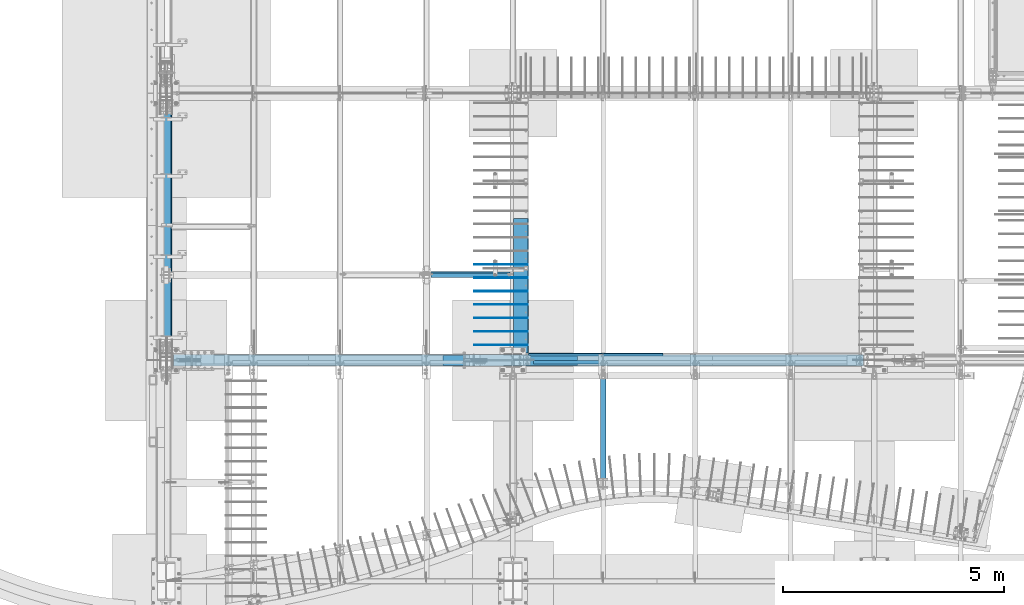
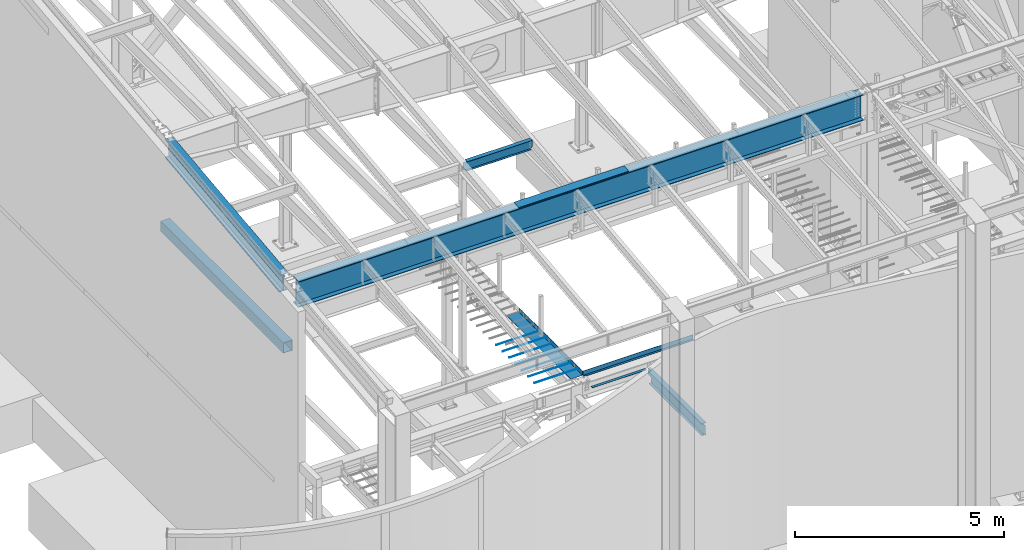
# One storey, part 706 of 1179: 16 beams, 14 elements without a shape of their own.
"""IFC2X3 building model written with IfcOpenShell, lengths in millimetres."""

from ifc_helpers import new_model, si_unit, frame, origin_with_axes, place, context, subcontext, project, spatial, faceted_brep, material, type_object, element, aggregate, save


model = new_model("IFC2X3")

# Units and contexts
model_context = context("Model", 3, precision=1e-05, world=origin_with_axes())
body_context = subcontext(model_context, "Body", "Model", "MODEL_VIEW")
ifc_project = project(units=[si_unit("LENGTHUNIT", "METRE", prefix="MILLI"), si_unit("AREAUNIT", "SQUARE_METRE"), si_unit("VOLUMEUNIT", "CUBIC_METRE"), si_unit("MASSUNIT", "GRAM", prefix="KILO"), si_unit("TIMEUNIT", "SECOND"), si_unit("PLANEANGLEUNIT", "RADIAN"), si_unit("SOLIDANGLEUNIT", "STERADIAN"), si_unit("THERMODYNAMICTEMPERATUREUNIT", "DEGREE_CELSIUS"), si_unit("LUMINOUSINTENSITYUNIT", "LUMEN")], contexts=[model_context])

# Site, building, storey
site_placement = place(None, origin_with_axes())
site = spatial("IfcSite", under=ifc_project, at=site_placement, CompositionType="ELEMENT")
building_placement = place(site_placement, origin_with_axes())
building = spatial("IfcBuilding", under=site, at=building_placement, Name="Undefined", CompositionType="ELEMENT")
storey_placement = place(building_placement, origin_with_axes())
storey = spatial("IfcBuildingStorey", under=building, at=storey_placement, Name="Undefined", CompositionType="ELEMENT", Elevation=0.0)

# Assembly, beam
assembly_1_placement = place(storey_placement, origin_with_axes())
assembly_1 = element("IfcElementAssembly", 1, at=assembly_1_placement, inside=storey, Name="BEAM", AssemblyPlace="NOTDEFINED", PredefinedType="RIGID_FRAME")
ifc_material_1 = material(Name="STEEL/A992")
beam_type_1 = type_object("IfcBeamType", Name="W12X14", PredefinedType="NOTDEFINED")
beam_1_placement = place(assembly_1_placement, frame((6324.6, 7382.95051456451, 9929.37147871498), z_axis=(0.0, -0.11280435903861, 0.993617218340085), x_axis=(1.0, 0.0, 0.0)))
beam_1 = element("IfcBeam", 2, at=beam_1_placement, type_object=beam_type_1, material=ifc_material_1, Name="BEAM", ObjectType="W12X14", context=body_context, shape_type="Brep", body=[
    faceted_brep([(15.875, -2.38124999998217, -125.412500001823), (15.875, 2.38125000001673, -125.412500001821), (85.725000190735, 2.38125000001673, -125.412500001734), (85.725000190735, -2.38124999998035, -125.412500001727), (90.5850797087805, 2.38125000001673, -126.379229924321), (90.5850797087805, -2.38124999998035, -126.379229924314), (94.7052561769342, 2.38125000001855, -129.132243824804), (94.7052561769342, -2.38124999998035, -129.132243824799), (97.4582700774126, 2.38125000001855, -133.252420292965), (97.4582700774126, -2.38124999998035, -133.252420292958), (98.4250000000002, -2.38124999997854, -138.112499811014), (98.4250000000002, 2.38125000001855, -138.112499811021), (98.4250000000002, 2.38125000002037, -144.462500000087), (98.4250000000002, 50.7999999999993, -144.46250000012), (98.4250000000002, 50.8000000000011, -150.812500000122), (98.4250000000002, -50.7999999999574, -150.812500000055), (98.4250000000002, -50.7999999999574, -144.462500000051), (98.4250000000002, -2.38124999997854, -144.462500000083), (1889.91875, 50.7999999999593, 144.462500000054), (1889.91875, 2.38124999997854, 144.462500000085), (98.4250000000002, 2.38124999997854, 144.462500000085), (98.4250000000002, 50.7999999999593, 144.462500000054), (85.725000190735, -2.38125000001673, 125.412499998731), (85.725000190735, 2.38124999998035, 125.412499998723), (15.875, 2.38124999998217, 125.412499998634), (15.875, -2.38125000001673, 125.412499998632), (90.5850797087805, -2.38125000001673, 126.379229921322), (90.5850797087805, 2.38124999998217, 126.379229921315), (94.7052561769342, -2.38125000001673, 129.132243821803), (94.7052561769342, 2.38124999998035, 129.132243821796), (97.4582700774126, -2.38125000001855, 133.252420289966), (97.4582700774126, 2.38124999998035, 133.252420289959), (98.4250000000002, -2.38125000001855, 138.112499808019), (98.4250000000002, 2.38124999998035, 138.11249980801), (1889.91875, -50.7999999999993, 150.812500000124), (1889.91875, 50.7999999999574, 150.812500000058), (98.4250000000002, 50.7999999999574, 150.812500000058), (98.4250000000002, -50.7999999999993, 150.812500000124), (1889.91875, -50.7999999999993, 144.46250000012), (98.4250000000002, -50.7999999999993, 144.46250000012), (1889.91875, -2.38125000001855, 144.462500000089), (98.4250000000002, -2.38125000001855, 144.462500000089), (1890.88547992258, -2.38125000001855, 139.602420289955), (1890.88547992258, 2.38124999998035, 139.60242028995), (1893.63849382306, -2.38125000001855, 135.482243821796), (1893.63849382306, 2.38124999998035, 135.482243821787), (1897.75867029122, -2.38125000001855, 132.729229921311), (1897.75867029122, 2.38124999998035, 132.729229921306), (1902.61874980926, -2.38125000001855, 131.762499998722), (1902.61874980926, 2.38124999998035, 131.762499998715), (1940.71875, -2.38125000001673, 131.762499998811), (1940.71875, 2.38124999998035, 131.762499998813), (1940.71875, 2.38125000001673, -117.887500003169), (1940.71875, 2.38124999998399, 112.712499998535), (1940.71875, -2.38124999998035, -131.762500001627), (1940.71875, 2.38125000001855, -131.762500001627), (1902.61874980926, -2.38124999998035, -131.76250000172), (1902.61874980926, 2.38125000001855, -131.762500001725), (1897.75867029122, -2.38124999997854, -132.729229924307), (1897.75867029122, 2.38125000001855, -132.729229924314), (1893.63849382306, -2.38124999997854, -135.48224382479), (1893.63849382306, 2.38125000001855, -135.482243824797), (1890.88547992258, -2.38124999997854, -139.602420292951), (1890.88547992258, 2.38125000001855, -139.602420292958), (1889.91875, -2.38124999997854, -144.462500000083), (1889.91875, 2.38125000002037, -144.462500000087), (1889.91875, -50.7999999999574, -144.462500000051), (1889.91875, -50.7999999999574, -150.812500000055), (1889.91875, 50.8000000000011, -150.812500000122), (1889.91875, 50.7999999999993, -144.46250000012), (15.875, 2.38125000001673, -117.887500002969), (15.875, 2.38124999998399, 112.71249999857)], [[[0, 1, 2, 3]], [[3, 2, 4, 5]], [[5, 4, 6, 7]], [[7, 6, 8, 9]], [[10, 11, 12, 13, 14, 15, 16, 17]], [[9, 8, 11, 10]], [[18, 19, 20, 21]], [[22, 23, 24, 25]], [[26, 27, 23, 22]], [[28, 29, 27, 26]], [[30, 31, 29, 28]], [[32, 33, 31, 30]], [[34, 35, 36, 37]], [[38, 34, 37, 39]], [[40, 38, 39, 41]], [[37, 36, 21, 20, 33, 32, 41, 39]], [[35, 18, 21, 36]], [[34, 38, 40, 19, 18, 35]], [[42, 43, 19, 40]], [[44, 45, 43, 42]], [[46, 47, 45, 44]], [[48, 49, 47, 46]], [[50, 51, 49, 48]], [[52, 53, 51, 50, 54, 55]], [[54, 56, 57, 55]], [[58, 59, 57, 56]], [[60, 61, 59, 58]], [[62, 63, 61, 60]], [[64, 65, 63, 62]], [[66, 67, 68, 69, 65, 64]], [[66, 64, 17, 16]], [[67, 66, 16, 15]], [[68, 67, 15, 14]], [[69, 68, 14, 13]], [[65, 69, 13, 12]], [[6, 4, 2, 1, 70, 71, 24, 23, 27, 29, 31, 33, 20, 19, 43, 45, 47, 49, 51, 53, 52, 55, 57, 59, 61, 63, 65, 12, 11, 8]], [[25, 24, 71, 70, 1, 0]], [[64, 62, 60, 58, 56, 54, 50, 48, 46, 44, 42, 40, 41, 32, 30, 28, 26, 22, 25, 0, 3, 5, 7, 9, 10, 17]]]),
])
aggregate(assembly_1, [beam_1])

assembly_2_placement = place(storey_placement, origin_with_axes())
assembly_2 = element("IfcElementAssembly", 3, at=assembly_2_placement, inside=storey, Name="BEAM", AssemblyPlace="NOTDEFINED", PredefinedType="RIGID_FRAME")
ifc_material_2 = material(Name="STEEL/A36")
beam_type_2 = type_object("IfcBeamType", PredefinedType="NOTDEFINED")
beam_2_placement = place(assembly_2_placement, frame((10150.475, 5597.525, 4235.45000610352), z_axis=(1.0, 0.0, 0.0), x_axis=(0.0, 0.0, -1.0)))
beam_2 = element("IfcBeam", 4, at=beam_2_placement, type_object=beam_type_2, material=ifc_material_2, Name="BENT_PLATE", context=body_context, shape_type="Brep", body=[
    faceted_brep([(133.350006103516, -47.6250000000027, -1463.675), (127.000006103515, -47.6250000000027, -1463.675), (127.000006103512, -47.6249999999927, -1524.0), (133.350006103512, -47.6249999999927, -1524.0), (133.350006103516, -60.3250000000016, -1463.675), (127.000006103515, -60.3250000000016, -1463.675), (0.0, 3.17499999999927, -1524.0), (6.00266503170133e-10, 3.17500000077416, 1524.00000000052), (133.350006103513, 3.17500000000291, 1524.0), (133.350006103513, 3.17500000000291, -1524.0), (0.0, -3.17499999999927, -1524.0), (6.00266503170133e-10, -3.17499999922438, 1524.00000000052), (127.000006103513, -3.17500000000291, -1524.0), (127.000006103513, -3.17500000000291, 1524.0), (127.000006103515, -60.3250000000016, 1524.0), (133.350006103516, -60.3250000000016, 1524.0)], [[[0, 1, 2, 3]], [[4, 5, 1, 0]], [[6, 7, 8, 9]], [[10, 11, 7, 6]], [[11, 10, 12, 13]], [[8, 7, 11, 13, 14, 15]], [[3, 9, 8, 15, 4, 0]], [[12, 10, 6, 9, 3, 2]], [[14, 13, 12, 2, 1, 5]], [[15, 14, 5, 4]]]),
])

assembly_3_placement = place(storey_placement, origin_with_axes())
assembly_3 = element("IfcElementAssembly", 5, at=assembly_3_placement, inside=storey, Name="BEAM", AssemblyPlace="NOTDEFINED", PredefinedType="RIGID_FRAME")
beam_type_3 = type_object("IfcBeamType", PredefinedType="NOTDEFINED")
beam_3_placement = place(assembly_3_placement, frame((8220.07499932826, 5543.55933465687, 9826.91628422072), z_axis=(-1.0, 0.0, 0.0), x_axis=(0.0, 0.0, 1.0)))
beam_3 = element("IfcBeam", 6, at=beam_3_placement, type_object=beam_type_3, material=ifc_material_2, Name="BENT_PLATE", context=body_context, shape_type="Brep", body=[
    faceted_brep([(-2.91038304567337e-11, -4.76250000000073, -1524.0), (-2.91038304567337e-11, -4.76250000000073, 1524.0), (2.91038304567337e-11, 4.76250000000073, 1524.0), (2.91038304567337e-11, 4.76250000000073, -1524.0), (46.9151566473611, 4.76249999974698, 1524.0), (46.9151566473611, 4.76249999974698, -1524.0), (36.2535598523627, -4.76250000019536, -1524.0), (36.2535598523627, -4.76250000019536, 1524.0), (21.449529282756, -220.662499999238, 1524.0), (21.449529282756, -220.662499999238, -1524.0), (12.939957335464, -211.13749999934, -1524.0), (12.939957335464, -211.13749999934, 1524.0), (1.17463059723377e-07, -220.662499999494, 1524.0), (1.17463059723377e-07, -220.662499999494, -1524.0), (1.17350282380357e-07, -211.137499999494, 1524.0), (1.17350282380357e-07, -211.137499999494, -1524.0)], [[[0, 1, 2, 3]], [[3, 2, 4, 5]], [[1, 0, 6, 7]], [[5, 4, 8, 9]], [[7, 6, 10, 11]], [[9, 8, 12, 13]], [[8, 4, 2, 1, 7, 11, 14, 12]], [[11, 10, 15, 14]], [[10, 6, 0, 3, 5, 9, 13, 15]], [[14, 15, 13, 12]]]),
])

# Beam
beam_type_4 = type_object("IfcBeamType", PredefinedType="NOTDEFINED")
beam_4_placement = place(assembly_2_placement, frame((8750.29999928457, 5390.35625, 3844.13073387436), z_axis=(0.0, 1.0, 0.0), x_axis=(1.0, 0.0, 0.0)))
beam_4 = element("IfcBeam", 7, at=beam_4_placement, type_object=beam_type_4, material=ifc_material_2, Name="PLATE", context=body_context, shape_type="Brep", body=[
    faceted_brep([(0.0, 3.96900000000005, -38.1000000000004), (0.0, 3.96900000000005, 38.1000000000004), (1498.60000071543, 3.96899999998413, 38.1000000000004), (1498.60000071543, 3.96899999998413, -38.1000000000004), (-3.63797880709171e-12, -3.96900000000005, 38.1000000000004), (1498.60000071543, -3.96900000001551, 38.1000000000004), (-3.63797880709171e-12, -3.96900000000005, -38.1000000000004), (1498.60000071543, -3.96900000001551, -38.1000000000004)], [[[0, 1, 2, 3]], [[1, 4, 5, 2]], [[4, 6, 7, 5]], [[6, 0, 3, 7]], [[5, 7, 3, 2]], [[6, 4, 1, 0]]]),
])

aggregate(assembly_2, [beam_2, beam_4])

# Assembly, beam
assembly_4_placement = place(storey_placement, origin_with_axes())
assembly_4 = element("IfcElementAssembly", 8, at=assembly_4_placement, inside=storey, Name="#4 DOWEL", AssemblyPlace="NOTDEFINED", PredefinedType="NOTDEFINED")
ifc_material_3 = material(Name="REBAR/A615-40")
beam_type_5 = type_object("IfcBeamType", Name="#4 DOWEL", PredefinedType="NOTDEFINED")
beam_5_placement = place(assembly_4_placement, frame((7400.925, 7610.475, 4203.70000610352), z_axis=(0.0, 0.0, 1.0), x_axis=(1.0, 0.0, 0.0)))
beam_5 = element("IfcBeam", 9, at=beam_5_placement, type_object=beam_type_5, material=ifc_material_3, Name="#4 DOWEL", ObjectType="#4 DOWEL", context=body_context, shape_type="Brep", body=[
    faceted_brep([(0.0, -6.34999999999854, 0.0), (0.0, -4.49012806053361, -4.49012806053452), (1219.2, -4.49012806053543, -4.49012806053452), (1219.2, -6.35000000000036, 0.0), (0.0, 0.0, -6.34999999999991), (1219.2, 0.0, -6.35000000000036), (0.0, 4.49012806053361, -4.49012806053452), (1219.2, 4.49012806053543, -4.49012806053452), (0.0, 6.34999999999854, 0.0), (1219.2, 6.35000000000036, 0.0), (0.0, 4.49012806053361, 4.49012806053452), (1219.2, 4.49012806053543, 4.49012806053452), (0.0, 0.0, 6.34999999999991), (1219.2, 0.0, 6.35000000000036), (0.0, -4.49012806053361, 4.49012806053452), (1219.2, -4.49012806053543, 4.49012806053452)], [[[0, 1, 2, 3]], [[1, 4, 5, 2]], [[4, 6, 7, 5]], [[6, 8, 9, 7]], [[8, 10, 11, 9]], [[10, 12, 13, 11]], [[12, 14, 15, 13]], [[14, 0, 3, 15]], [[5, 7, 9, 11, 13, 15, 3, 2]], [[14, 12, 10, 8, 6, 4, 1, 0]]]),
])
aggregate(assembly_4, [beam_5])

assembly_5_placement = place(storey_placement, origin_with_axes())
assembly_5 = element("IfcElementAssembly", 10, at=assembly_5_placement, inside=storey, Name="#4 DOWEL", AssemblyPlace="NOTDEFINED", PredefinedType="NOTDEFINED")
beam_6_placement = place(assembly_5_placement, frame((7400.925, 7305.675, 4203.70000610352), z_axis=(0.0, 0.0, 1.0), x_axis=(1.0, 0.0, 0.0)))
beam_6 = element("IfcBeam", 11, at=beam_6_placement, type_object=beam_type_5, material=ifc_material_3, Name="#4 DOWEL", ObjectType="#4 DOWEL", context=body_context, shape_type="Brep", body=[
    faceted_brep([(0.0, -6.34999999999854, 0.0), (0.0, -4.49012806053361, -4.49012806053452), (1219.2, -4.49012806053543, -4.49012806053452), (1219.2, -6.35000000000036, 0.0), (0.0, 0.0, -6.34999999999991), (1219.2, 0.0, -6.35000000000036), (0.0, 4.49012806053361, -4.49012806053452), (1219.2, 4.49012806053543, -4.49012806053452), (0.0, 6.34999999999854, 0.0), (1219.2, 6.35000000000036, 0.0), (0.0, 4.49012806053361, 4.49012806053452), (1219.2, 4.49012806053543, 4.49012806053452), (0.0, 0.0, 6.34999999999991), (1219.2, 0.0, 6.35000000000036), (0.0, -4.49012806053361, 4.49012806053452), (1219.2, -4.49012806053543, 4.49012806053452)], [[[0, 1, 2, 3]], [[1, 4, 5, 2]], [[4, 6, 7, 5]], [[6, 8, 9, 7]], [[8, 10, 11, 9]], [[10, 12, 13, 11]], [[12, 14, 15, 13]], [[14, 0, 3, 15]], [[5, 7, 9, 11, 13, 15, 3, 2]], [[14, 12, 10, 8, 6, 4, 1, 0]]]),
])
aggregate(assembly_5, [beam_6])

assembly_6_placement = place(storey_placement, origin_with_axes())
assembly_6 = element("IfcElementAssembly", 12, at=assembly_6_placement, inside=storey, Name="#4 DOWEL", AssemblyPlace="NOTDEFINED", PredefinedType="NOTDEFINED")
beam_7_placement = place(assembly_6_placement, frame((7400.925, 7000.875, 4203.70000610352), z_axis=(0.0, 0.0, 1.0), x_axis=(1.0, 0.0, 0.0)))
beam_7 = element("IfcBeam", 13, at=beam_7_placement, type_object=beam_type_5, material=ifc_material_3, Name="#4 DOWEL", ObjectType="#4 DOWEL", context=body_context, shape_type="Brep", body=[
    faceted_brep([(0.0, -6.34999999999854, 0.0), (0.0, -4.49012806053361, -4.49012806053452), (1219.2, -4.49012806053543, -4.49012806053452), (1219.2, -6.35000000000036, 0.0), (0.0, 0.0, -6.34999999999991), (1219.2, 0.0, -6.35000000000036), (0.0, 4.49012806053361, -4.49012806053452), (1219.2, 4.49012806053543, -4.49012806053452), (0.0, 6.34999999999854, 0.0), (1219.2, 6.35000000000036, 0.0), (0.0, 4.49012806053361, 4.49012806053452), (1219.2, 4.49012806053543, 4.49012806053452), (0.0, 0.0, 6.34999999999991), (1219.2, 0.0, 6.35000000000036), (0.0, -4.49012806053361, 4.49012806053452), (1219.2, -4.49012806053543, 4.49012806053452)], [[[0, 1, 2, 3]], [[1, 4, 5, 2]], [[4, 6, 7, 5]], [[6, 8, 9, 7]], [[8, 10, 11, 9]], [[10, 12, 13, 11]], [[12, 14, 15, 13]], [[14, 0, 3, 15]], [[5, 7, 9, 11, 13, 15, 3, 2]], [[14, 12, 10, 8, 6, 4, 1, 0]]]),
])
aggregate(assembly_6, [beam_7])

assembly_7_placement = place(storey_placement, origin_with_axes())
assembly_7 = element("IfcElementAssembly", 14, at=assembly_7_placement, inside=storey, Name="#4 DOWEL", AssemblyPlace="NOTDEFINED", PredefinedType="NOTDEFINED")
beam_8_placement = place(assembly_7_placement, frame((7400.925, 6696.075, 4203.70000610352), z_axis=(0.0, 0.0, 1.0), x_axis=(1.0, 0.0, 0.0)))
beam_8 = element("IfcBeam", 15, at=beam_8_placement, type_object=beam_type_5, material=ifc_material_3, Name="#4 DOWEL", ObjectType="#4 DOWEL", context=body_context, shape_type="Brep", body=[
    faceted_brep([(0.0, -6.34999999999854, 0.0), (0.0, -4.49012806053361, -4.49012806053452), (1219.2, -4.49012806053543, -4.49012806053452), (1219.2, -6.35000000000036, 0.0), (0.0, 0.0, -6.34999999999991), (1219.2, 0.0, -6.35000000000036), (0.0, 4.49012806053361, -4.49012806053452), (1219.2, 4.49012806053543, -4.49012806053452), (0.0, 6.34999999999854, 0.0), (1219.2, 6.35000000000036, 0.0), (0.0, 4.49012806053361, 4.49012806053452), (1219.2, 4.49012806053543, 4.49012806053452), (0.0, 0.0, 6.34999999999991), (1219.2, 0.0, 6.35000000000036), (0.0, -4.49012806053361, 4.49012806053452), (1219.2, -4.49012806053543, 4.49012806053452)], [[[0, 1, 2, 3]], [[1, 4, 5, 2]], [[4, 6, 7, 5]], [[6, 8, 9, 7]], [[8, 10, 11, 9]], [[10, 12, 13, 11]], [[12, 14, 15, 13]], [[14, 0, 3, 15]], [[5, 7, 9, 11, 13, 15, 3, 2]], [[14, 12, 10, 8, 6, 4, 1, 0]]]),
])
aggregate(assembly_7, [beam_8])

assembly_8_placement = place(storey_placement, origin_with_axes())
assembly_8 = element("IfcElementAssembly", 16, at=assembly_8_placement, inside=storey, Name="#4 DOWEL", AssemblyPlace="NOTDEFINED", PredefinedType="NOTDEFINED")
beam_9_placement = place(assembly_8_placement, frame((7400.925, 6391.275, 4203.70000610352), z_axis=(0.0, 0.0, 1.0), x_axis=(1.0, 0.0, 0.0)))
beam_9 = element("IfcBeam", 17, at=beam_9_placement, type_object=beam_type_5, material=ifc_material_3, Name="#4 DOWEL", ObjectType="#4 DOWEL", context=body_context, shape_type="Brep", body=[
    faceted_brep([(0.0, -6.34999999999854, 0.0), (0.0, -4.49012806053361, -4.49012806053452), (1219.2, -4.49012806053543, -4.49012806053452), (1219.2, -6.35000000000036, 0.0), (0.0, 0.0, -6.34999999999991), (1219.2, 0.0, -6.35000000000036), (0.0, 4.49012806053361, -4.49012806053452), (1219.2, 4.49012806053543, -4.49012806053452), (0.0, 6.34999999999854, 0.0), (1219.2, 6.35000000000036, 0.0), (0.0, 4.49012806053361, 4.49012806053452), (1219.2, 4.49012806053543, 4.49012806053452), (0.0, 0.0, 6.34999999999991), (1219.2, 0.0, 6.35000000000036), (0.0, -4.49012806053361, 4.49012806053452), (1219.2, -4.49012806053543, 4.49012806053452)], [[[0, 1, 2, 3]], [[1, 4, 5, 2]], [[4, 6, 7, 5]], [[6, 8, 9, 7]], [[8, 10, 11, 9]], [[10, 12, 13, 11]], [[12, 14, 15, 13]], [[14, 0, 3, 15]], [[5, 7, 9, 11, 13, 15, 3, 2]], [[14, 12, 10, 8, 6, 4, 1, 0]]]),
])
aggregate(assembly_8, [beam_9])

assembly_9_placement = place(storey_placement, origin_with_axes())
assembly_9 = element("IfcElementAssembly", 18, at=assembly_9_placement, inside=storey, Name="#4 DOWEL", AssemblyPlace="NOTDEFINED", PredefinedType="NOTDEFINED")
beam_10_placement = place(assembly_9_placement, frame((7400.925, 6086.475, 4203.70000610352), z_axis=(0.0, 0.0, 1.0), x_axis=(1.0, 0.0, 0.0)))
beam_10 = element("IfcBeam", 19, at=beam_10_placement, type_object=beam_type_5, material=ifc_material_3, Name="#4 DOWEL", ObjectType="#4 DOWEL", context=body_context, shape_type="Brep", body=[
    faceted_brep([(0.0, -6.34999999999854, 0.0), (0.0, -4.49012806053361, -4.49012806053452), (1219.2, -4.49012806053543, -4.49012806053452), (1219.2, -6.35000000000036, 0.0), (0.0, 0.0, -6.34999999999991), (1219.2, 0.0, -6.35000000000036), (0.0, 4.49012806053361, -4.49012806053452), (1219.2, 4.49012806053543, -4.49012806053452), (0.0, 6.34999999999854, 0.0), (1219.2, 6.35000000000036, 0.0), (0.0, 4.49012806053361, 4.49012806053452), (1219.2, 4.49012806053543, 4.49012806053452), (0.0, 0.0, 6.34999999999991), (1219.2, 0.0, 6.35000000000036), (0.0, -4.49012806053361, 4.49012806053452), (1219.2, -4.49012806053543, 4.49012806053452)], [[[0, 1, 2, 3]], [[1, 4, 5, 2]], [[4, 6, 7, 5]], [[6, 8, 9, 7]], [[8, 10, 11, 9]], [[10, 12, 13, 11]], [[12, 14, 15, 13]], [[14, 0, 3, 15]], [[5, 7, 9, 11, 13, 15, 3, 2]], [[14, 12, 10, 8, 6, 4, 1, 0]]]),
])
aggregate(assembly_9, [beam_10])

assembly_10_placement = place(storey_placement, origin_with_axes())
assembly_10 = element("IfcElementAssembly", 20, at=assembly_10_placement, inside=storey, Name="#4 DOWEL", AssemblyPlace="NOTDEFINED", PredefinedType="NOTDEFINED")
beam_11_placement = place(assembly_10_placement, frame((7400.925, 5781.675, 4203.70000610352), z_axis=(0.0, 0.0, 1.0), x_axis=(1.0, 0.0, 0.0)))
beam_11 = element("IfcBeam", 21, at=beam_11_placement, type_object=beam_type_5, material=ifc_material_3, Name="#4 DOWEL", ObjectType="#4 DOWEL", context=body_context, shape_type="Brep", body=[
    faceted_brep([(0.0, -6.34999999999854, 0.0), (0.0, -4.49012806053361, -4.49012806053452), (1219.2, -4.49012806053543, -4.49012806053452), (1219.2, -6.35000000000036, 0.0), (0.0, 0.0, -6.34999999999991), (1219.2, 0.0, -6.35000000000036), (0.0, 4.49012806053361, -4.49012806053452), (1219.2, 4.49012806053543, -4.49012806053452), (0.0, 6.34999999999854, 0.0), (1219.2, 6.35000000000036, 0.0), (0.0, 4.49012806053361, 4.49012806053452), (1219.2, 4.49012806053543, 4.49012806053452), (0.0, 0.0, 6.34999999999991), (1219.2, 0.0, 6.35000000000036), (0.0, -4.49012806053361, 4.49012806053452), (1219.2, -4.49012806053543, 4.49012806053452)], [[[0, 1, 2, 3]], [[1, 4, 5, 2]], [[4, 6, 7, 5]], [[6, 8, 9, 7]], [[8, 10, 11, 9]], [[10, 12, 13, 11]], [[12, 14, 15, 13]], [[14, 0, 3, 15]], [[5, 7, 9, 11, 13, 15, 3, 2]], [[14, 12, 10, 8, 6, 4, 1, 0]]]),
])
aggregate(assembly_10, [beam_11])

assembly_11_placement = place(storey_placement, origin_with_axes())
assembly_11 = element("IfcElementAssembly", 22, at=assembly_11_placement, inside=storey, Name="BEAM", AssemblyPlace="NOTDEFINED", PredefinedType="RIGID_FRAME")
beam_type_6 = type_object("IfcBeamType", PredefinedType="NOTDEFINED")
beam_12_placement = place(assembly_11_placement, frame((8296.27498779297, 7127.875, 4105.275), z_axis=(0.0, -1.0, 0.0), x_axis=(1.0, 0.0, 0.0)))
beam_12 = element("IfcBeam", 23, at=beam_12_placement, type_object=beam_type_6, material=ifc_material_2, Name="BENT_PLATE", context=body_context, shape_type="Brep", body=[
    faceted_brep([(0.0, -3.17499999999927, -1524.0), (6.00266503170133e-10, -3.17499999922438, 1524.00000000052), (6.00266503170133e-10, 3.17500000077416, 1524.00000000052), (0.0, 3.17499999999927, -1524.0), (323.850012207033, 3.17500000000018, 1524.0), (323.850012207033, 3.17500000000018, -1524.0), (330.200012207031, -3.17500000000018, -1524.0), (330.200012207031, -3.17500000000018, 1524.0), (323.850012207033, 130.175006103515, 1524.0), (323.850012207033, 130.175006103515, -1524.0), (330.200012207031, 130.175006103515, 1524.0), (330.200012207031, 130.175006103515, -1524.0)], [[[0, 1, 2, 3]], [[3, 2, 4, 5]], [[1, 0, 6, 7]], [[5, 4, 8, 9]], [[4, 2, 1, 7, 10, 8]], [[7, 6, 11, 10]], [[6, 0, 3, 5, 9, 11]], [[10, 11, 9, 8]]]),
])
aggregate(assembly_11, [beam_12])

# Beam
beam_type_7 = type_object("IfcBeamType", Name="W30X90", PredefinedType="NOTDEFINED")
beam_13_placement = place(assembly_3_placement, frame((431.800005993724, 5435.60933465636, 9452.2662842795), z_axis=(0.0, 0.0, 1.0), x_axis=(1.0, 0.0, 0.0)))
beam_13 = element("IfcBeam", 24, at=beam_13_placement, type_object=beam_type_7, material=ifc_material_1, Name="BEAM", ObjectType="W30X90", context=body_context, shape_type="Brep", body=[
    faceted_brep([(168.274994006281, -131.7625, -374.65), (168.274994006281, 131.7625, -374.65), (15779.7499940063, 131.7625, -374.65), (15779.7499940063, -131.7625, -374.65), (168.274994006281, -131.7625, -358.775), (168.274994006281, -6.35000000000036, -358.775), (168.274994006281, -6.35000000000036, 358.775), (168.274994006281, -131.7625, 358.775), (168.274994006281, -131.7625, 374.65), (168.274994006281, 131.7625, 374.65), (168.274994006281, 131.7625, 358.775), (168.274994006281, 6.35000000000036, 358.775), (168.274994006281, 6.35000000000036, -358.775), (168.274994006281, 131.7625, -358.775), (15779.7499940063, -131.7625, -358.775), (15779.7499940063, -6.35000000000036, -358.775), (15779.7499940063, -6.35000000000036, 358.775), (15779.7499940063, -131.7625, 358.775), (15779.7499940063, -131.7625, 374.65), (15779.7499940063, 131.7625, 374.65), (15779.7499940063, 131.7625, 358.775), (15779.7499940063, 6.35000000000036, 358.775), (15779.7499940063, 6.35000000000036, 318.240000185564), (15779.7499940063, 6.35000000000036, -305.539999814642), (15779.7499940063, 6.35000000000036, -358.775), (15779.7499940063, 131.7625, -358.775)], [[[0, 1, 2, 3]], [[0, 4, 5, 6, 7, 8, 9, 10, 11, 12, 13, 1]], [[5, 4, 14, 15]], [[6, 5, 15, 16]], [[7, 6, 16, 17]], [[8, 7, 17, 18]], [[9, 8, 18, 19]], [[10, 9, 19, 20]], [[11, 10, 20, 21]], [[12, 11, 21, 22, 23, 24]], [[13, 12, 24, 25]], [[1, 13, 25, 2]], [[24, 23, 22, 21, 20, 19, 18, 17, 16, 15, 14, 3, 2, 25]], [[4, 0, 3, 14]]]),
])

aggregate(assembly_3, [beam_3, beam_13])

# Assembly, beam
assembly_12_placement = place(storey_placement, origin_with_axes())
assembly_12 = element("IfcElementAssembly", 25, at=assembly_12_placement, inside=storey, Name="BEAM", AssemblyPlace="NOTDEFINED", PredefinedType="RIGID_FRAME")
beam_type_8 = type_object("IfcBeamType", Name="W21X93", PredefinedType="NOTDEFINED")
beam_14_placement = place(assembly_12_placement, frame((431.800000000002, 5466.44675635096, 9588.19603969819), z_axis=(0.0, -0.112284087038017, 0.993676146336441), x_axis=(0.0, 0.993676146336441, 0.112284087038017)))
beam_14 = element("IfcBeam", 26, at=beam_14_placement, type_object=beam_type_8, material=ifc_material_1, Name="BEAM", ObjectType="W21X93", context=body_context, shape_type="Brep", body=[
    faceted_brep([(258.811716651647, -106.3625, -250.825000000015), (258.811716651671, -106.3625, -274.637500000004), (5761.18622133681, -106.362499999999, -274.6375000028), (5763.87700226421, -106.362499999999, -250.825000002811), (258.811716651647, -7.14375000000001, -250.825000000015), (5763.87700226421, -7.14374999999927, -250.825000002811), (258.811716651141, -7.14375000000001, 250.824999999753), (5769.87796061358, -7.14375000000001, -197.718550778902), (5814.53171906201, -7.14375000000001, 197.452089917255), (5820.56278713472, -7.14374999999927, 250.824999996928), (258.811716651141, -106.3625, 250.824999999753), (5820.56278713472, -106.362499999999, 250.824999996928), (258.811716651117, -106.3625, 274.637499999742), (5823.25356806212, -106.362499999999, 274.637499996918), (258.811716651117, 106.3625, 274.637499999742), (5823.25356806212, 106.362499999999, 274.637499996918), (258.811716651141, 106.3625, 250.824999999753), (5820.56278713472, 106.362499999999, 250.824999996928), (258.811716651141, 7.14375000000001, 250.824999999753), (5820.56278713472, 7.14374999999927, 250.824999996928), (258.811716651647, 7.14375000000001, -250.825000000015), (5763.87700226421, 7.14374999999927, -250.825000002811), (258.811716651647, 106.3625, -250.825000000015), (5763.87700226421, 106.362499999999, -250.825000002811), (258.811716651671, 106.3625, -274.637500000004), (5761.18622133681, 106.362499999999, -274.6375000028)], [[[0, 1, 2, 3]], [[4, 0, 3, 5]], [[6, 4, 5, 7, 8, 9]], [[10, 6, 9, 11]], [[12, 10, 11, 13]], [[14, 12, 13, 15]], [[16, 14, 15, 17]], [[18, 16, 17, 19]], [[20, 18, 19, 21]], [[22, 20, 21, 23]], [[1, 0, 4, 6, 10, 12, 14, 16, 18, 20, 22, 24]], [[1, 24, 25, 2]], [[21, 19, 17, 15, 13, 11, 9, 8, 7, 5, 3, 2, 25, 23]], [[24, 22, 23, 25]]]),
])
aggregate(assembly_12, [beam_14])

assembly_13_placement = place(storey_placement, origin_with_axes())
assembly_13 = element("IfcElementAssembly", 27, at=assembly_13_placement, inside=storey, Name="BEAM", AssemblyPlace="NOTDEFINED", PredefinedType="RIGID_FRAME")
ifc_material_4 = material()
beam_type_9 = type_object("IfcBeamType", Name="HSS12X10X1/2", PredefinedType="NOTDEFINED")
beam_15_placement = place(assembly_13_placement, frame((431.800000000005, 5511.8, 7861.3), z_axis=(0.0, 0.0, 1.0), x_axis=(0.0, 1.0, 0.0)))
beam_15 = element("IfcBeam", 28, at=beam_15_placement, type_object=beam_type_9, material=ifc_material_4, Name="BEAM", ObjectType="HSS12X10X1/2", context=body_context, shape_type="Brep", body=[
    faceted_brep([(9.52500000000146, 114.299999999999, -139.7), (9.52500000000146, -114.299999999999, -139.7), (5881.6875, -114.3, -139.7), (5881.6875, 114.3, -139.7), (9.52500000000146, -114.299999999999, 139.7), (5881.6875, -114.3, 139.7), (9.52500000000146, 114.299999999999, 139.7), (5881.6875, 114.3, 139.7), (9.52500000000146, 127.0, -152.4), (9.52500000000146, 127.0, 152.4), (5881.6875, 127.0, 152.4), (5881.6875, 127.0, -152.4), (9.52500000000146, -127.0, 152.4), (5881.6875, -127.0, 152.4), (9.52500000000146, -127.0, -152.4), (5881.6875, -127.0, -152.4)], [[[0, 1, 2, 3]], [[1, 4, 5, 2]], [[4, 6, 7, 5]], [[6, 0, 3, 7]], [[8, 9, 10, 11]], [[9, 12, 13, 10]], [[12, 14, 15, 13]], [[14, 8, 11, 15]], [[13, 15, 11, 10], [5, 7, 3, 2]], [[14, 12, 9, 8], [6, 4, 1, 0]]]),
])
aggregate(assembly_13, [beam_15])

assembly_14_placement = place(storey_placement, origin_with_axes())
assembly_14 = element("IfcElementAssembly", 29, at=assembly_14_placement, inside=storey, Name="BEAM", AssemblyPlace="NOTDEFINED", PredefinedType="RIGID_FRAME")
beam_type_10 = type_object("IfcBeamType", Name="W14X26", PredefinedType="NOTDEFINED")
beam_16_placement = place(assembly_14_placement, frame((10325.1, 2647.95, 3671.8875), z_axis=(0.0, 0.0, 1.0), x_axis=(0.0, 1.0, 0.0)))
beam_16 = element("IfcBeam", 30, at=beam_16_placement, type_object=beam_type_10, material=ifc_material_1, Name="BEAM", ObjectType="W14X26", context=body_context, shape_type="Brep", body=[
    faceted_brep([(2620.9625003817, 28.5749995954666, 176.2125), (2620.9625003817, 28.5749995954666, 165.1), (2620.96250020706, 63.5, 165.1), (2620.96250020706, 63.5, 176.2125), (2622.89596027548, 18.8548405690453, 176.2125), (2622.89596027548, 18.8548405690453, 165.1), (2628.40198811764, 10.6144876602702, 176.2125), (2628.40198811764, 10.6144876602702, 165.1), (2636.64234108148, 5.10845990051894, 176.2125), (2636.64234108148, 5.10845990051894, 165.1), (2646.36250012724, 3.17500010394724, 176.2125), (2646.36250012724, 3.17499999999927, 165.1), (2755.10639088957, 3.17500064769047, 176.2125), (2755.10638849583, 3.17499999999927, 165.1), (95.2499884076783, 3.17499999999927, 165.1), (95.2499884076783, 63.5, 165.1), (101.665597189517, 63.5, 176.2125), (101.665597189517, -63.5, 176.2125), (2755.10638849583, -63.5, 176.2125), (2755.10638849583, -63.5, 165.1), (95.2499884076783, -63.5, 165.1), (2755.10638849583, -3.17499999999927, 165.1), (95.2499884076783, -3.17499999999927, 165.1), (95.020787505794, 3.17499999999927, 164.703000259399), (95.020787505794, -3.17499999999927, 164.703000259399), (117.474996948922, 3.17499999999927, 164.703000259399), (117.474996948922, -3.17499999999927, 164.703000259399), (133.804034531066, 3.17499999999927, 158.045004848507), (133.804034531066, -3.17499999999927, 158.045004848507), (137.888773595438, 3.17499999999927, 154.857742002601), (137.888773595438, -3.17499999999927, 154.857742002601), (139.700870417409, 3.17499999999927, 150.003873155928), (139.700870417409, -3.17499999999927, 150.003873155928), (138.704164947125, 3.17499999999927, 144.919552564306), (138.704164947125, -3.17499999999927, 144.919552564306), (135.193560662237, 3.17499999999927, 141.10912014425), (135.193560662237, -3.17499999999927, 141.10912014425), (130.207769040842, 3.17499999999927, 139.7), (130.207769040842, -3.17499999999927, 139.7), (15.8750000000027, 3.17499999999927, 139.7), (15.8750000000027, -3.17499999999927, 139.7), (15.8750000000027, 3.17499999999927, 138.112500000001), (15.8750000000027, 3.17499999999927, -92.4874999999997), (15.8750000000027, 3.17499999999927, -139.7), (15.8750000000027, -3.17499999999927, -139.7), (137.081772947067, 3.17499999999927, -139.7), (137.081772947067, -3.17499999999927, -139.7), (142.067564568461, 3.17499999999927, -141.10912014425), (142.067564568461, -3.17499999999927, -141.10912014425), (145.578168853349, 3.17499999999927, -144.919552564306), (145.578168853349, -3.17499999999927, -144.919552564306), (146.574874323633, 3.17499999999927, -150.003873155929), (146.574874323633, -3.17499999999927, -150.003873155929), (144.762777501662, 3.17499999999927, -154.857742002601), (144.762777501662, -3.17499999999927, -154.857742002601), (140.678038437291, 3.17499999999927, -158.045004848507), (140.678038437291, -3.17499999999927, -158.045004848507), (124.349000855147, 3.17499999999927, -164.703000259399), (124.349000855147, -3.17499999999927, -164.703000259399), (101.894810700874, 3.17499999999927, -164.703000259399), (101.894810700874, -3.17499999999927, -164.703000259399), (101.665622677133, -3.17499999999927, -165.1), (2620.96249811497, -3.17499999999927, -165.1), (2620.96249811497, -3.17499999999927, -36.5124996185305), (2622.89595796015, -3.17499999999927, -26.7923405824395), (2628.4019857611, -3.17499999999927, -18.5519876461321), (2636.64233869741, -3.17499999999927, -13.0459598451757), (2646.3624977335, -3.17499999999927, -11.1125000000002), (2755.10638849583, -3.17499999999927, -11.1125000000002), (95.2503743700081, 63.5, -176.2125), (101.665622677133, 63.5, -165.1), (2620.96249811497, 63.5, -165.1), (2620.96249811497, 63.5, -176.2125), (2620.96249811497, -63.5, -176.2125), (95.2503743700081, -63.5, -176.2125), (2620.96249811497, 28.5749995954666, -176.2125), (101.665622677133, -63.5, -165.1), (2620.96249811497, -63.5, -165.1), (101.665622677133, 3.17499999999927, -165.1), (2620.96249811497, 3.17499999999927, -165.1), (2620.96249811497, 28.5749995954666, -165.1), (2620.96249811497, 3.17499999999927, -36.5124996185305), (2622.89595796015, 3.17499999999927, -26.7923405824395), (2628.4019857611, 3.17499999999927, -18.5519876461321), (2636.64233869741, 3.17499999999927, -13.0459598451757), (2646.3624977335, 3.17499999999927, -11.1125000000002), (2755.10638849583, 3.17499999999927, -11.1125000000002)], [[[0, 1, 2, 3]], [[4, 5, 1, 0]], [[6, 7, 5, 4]], [[8, 9, 7, 6]], [[10, 11, 9, 8]], [[12, 13, 11, 10]], [[14, 15, 2, 1, 5, 7, 9, 11]], [[15, 16, 3, 2]], [[8, 6, 4, 0, 3, 16, 17, 18, 12, 10]], [[19, 18, 17, 20]], [[21, 19, 20, 22]], [[17, 16, 15, 14, 23, 24, 22, 20]], [[25, 26, 24, 23]], [[26, 25, 27, 28]], [[28, 27, 29, 30]], [[30, 29, 31, 32]], [[32, 31, 33, 34]], [[34, 33, 35, 36]], [[36, 35, 37, 38]], [[38, 37, 39, 40]], [[41, 42, 43, 44, 40, 39]], [[44, 43, 45, 46]], [[46, 45, 47, 48]], [[48, 47, 49, 50]], [[50, 49, 51, 52]], [[52, 51, 53, 54]], [[54, 53, 55, 56]], [[56, 55, 57, 58]], [[58, 57, 59, 60]], [[21, 22, 24, 26, 28, 30, 32, 34, 36, 38, 40, 44, 46, 48, 50, 52, 54, 56, 58, 60, 61, 62, 63, 64, 65, 66, 67, 68]], [[69, 70, 71, 72]], [[73, 74, 69, 72, 75]], [[76, 74, 73, 77]], [[61, 76, 77, 62]], [[60, 59, 78, 70, 69, 74, 76, 61]], [[71, 70, 78, 79, 80]], [[62, 77, 73, 75, 72, 71, 80, 79, 81, 63]], [[63, 81, 82, 64]], [[64, 82, 83, 65]], [[65, 83, 84, 66]], [[66, 84, 85, 67]], [[68, 67, 85, 86]], [[84, 83, 82, 81, 79, 78, 59, 57, 55, 53, 51, 49, 47, 45, 43, 42, 41, 39, 37, 35, 33, 31, 29, 27, 25, 23, 14, 11, 13, 86, 85]], [[18, 19, 21, 68, 86, 13, 12]]]),
])
aggregate(assembly_14, [beam_16])

save(model, "model.ifc")
